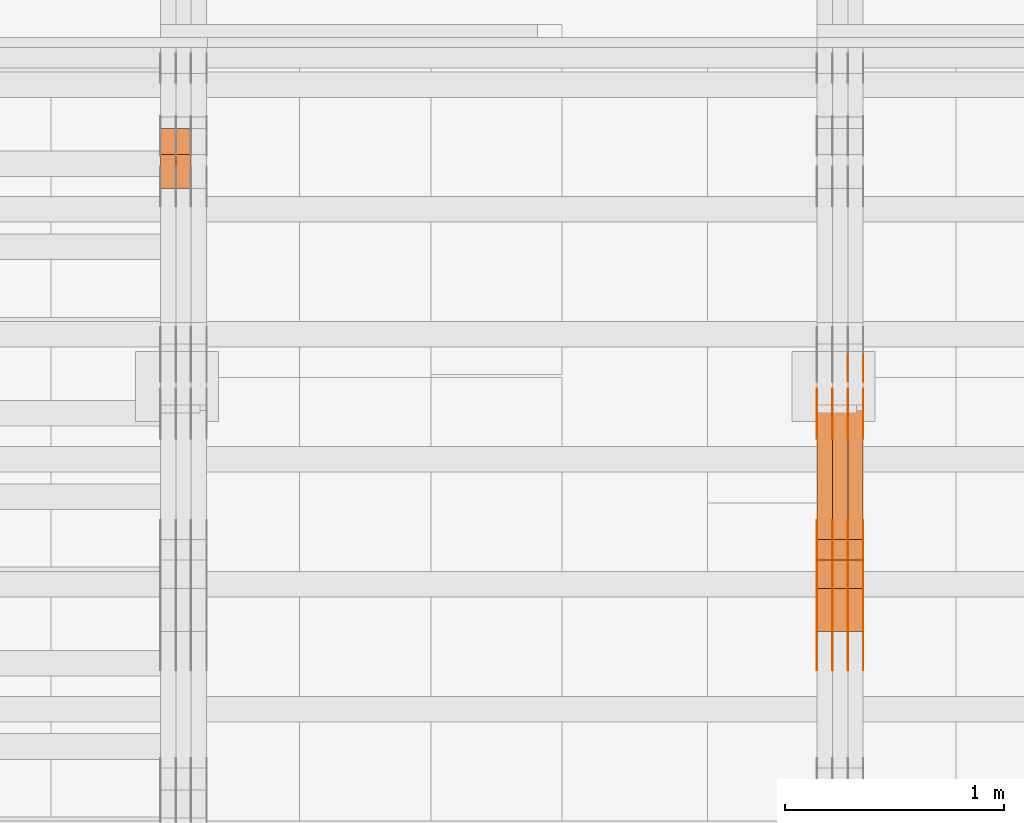
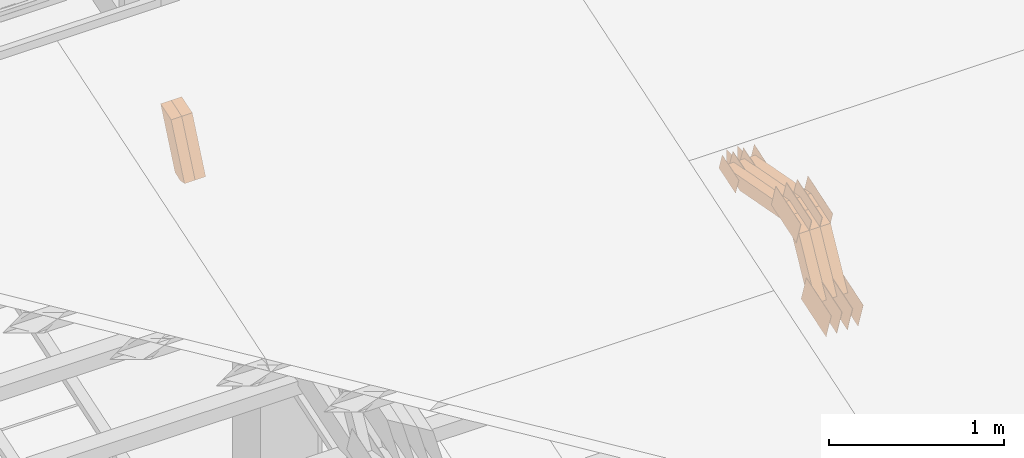
# One storey, part 79 of 385: 28 proxies.
"""IFC2X3 building model written with IfcOpenShell, lengths in millimetres."""

from ifc_helpers import new_model, entity, si_unit, converted_unit, derived_unit, direction, frame, frame_2d, origin, place, context, subcontext, project, spatial, polyline, rectangle, outline, extrude, source, transform, mapped, material, type_object, type_shapes, element, save


model = new_model("IFC2X3")

# Units and contexts
model_context = context("Model", 3, precision=0.01, world=origin(), true_north=direction((6.12303176911189e-17, 1.0)))
body_context = subcontext(model_context, "Body", "Model", "MODEL_VIEW")
ifc_project = project(units=[si_unit("LENGTHUNIT", "METRE", prefix="MILLI"), si_unit("AREAUNIT", "SQUARE_METRE"), si_unit("VOLUMEUNIT", "CUBIC_METRE"), converted_unit("PLANEANGLEUNIT", "DEGREE", entity("IfcRatioMeasure", 0.0174532925199433), si_unit("PLANEANGLEUNIT", "RADIAN"), dimensions=[0, 0, 0, 0, 0, 0, 0]), si_unit("MASSUNIT", "GRAM", prefix="KILO"), derived_unit("MASSDENSITYUNIT", [(si_unit("MASSUNIT", "GRAM", prefix="KILO"), 1), (si_unit("LENGTHUNIT", "METRE"), -3)]), si_unit("TIMEUNIT", "SECOND"), si_unit("FREQUENCYUNIT", "HERTZ"), si_unit("THERMODYNAMICTEMPERATUREUNIT", "DEGREE_CELSIUS"), derived_unit("THERMALTRANSMITTANCEUNIT", [(si_unit("MASSUNIT", "GRAM", prefix="KILO"), 1), (si_unit("THERMODYNAMICTEMPERATUREUNIT", "KELVIN"), -1), (si_unit("TIMEUNIT", "SECOND"), -3)]), derived_unit("VOLUMETRICFLOWRATEUNIT", [(si_unit("LENGTHUNIT", "METRE"), 3), (si_unit("TIMEUNIT", "SECOND"), -1)]), si_unit("ELECTRICCURRENTUNIT", "AMPERE"), si_unit("ELECTRICVOLTAGEUNIT", "VOLT"), si_unit("POWERUNIT", "WATT"), si_unit("FORCEUNIT", "NEWTON", prefix="KILO"), si_unit("ILLUMINANCEUNIT", "LUX"), si_unit("LUMINOUSFLUXUNIT", "LUMEN"), si_unit("LUMINOUSINTENSITYUNIT", "CANDELA"), derived_unit("USERDEFINED", [(si_unit("MASSUNIT", "GRAM", prefix="KILO"), -1), (si_unit("LENGTHUNIT", "METRE"), -2), (si_unit("TIMEUNIT", "SECOND"), 3), (si_unit("LUMINOUSFLUXUNIT", "LUMEN"), 1)]), derived_unit("LINEARVELOCITYUNIT", [(si_unit("LENGTHUNIT", "METRE"), 1), (si_unit("TIMEUNIT", "SECOND"), -1)]), si_unit("PRESSUREUNIT", "PASCAL"), derived_unit("USERDEFINED", [(si_unit("LENGTHUNIT", "METRE"), -2), (si_unit("MASSUNIT", "GRAM", prefix="KILO"), 1), (si_unit("TIMEUNIT", "SECOND"), -2)])], contexts=[model_context])

# Site, building, storey
site_placement = place(None, origin())
site = spatial("IfcSite", under=ifc_project, at=site_placement, CompositionType="ELEMENT")
building_placement = place(site_placement, origin())
building = spatial("IfcBuilding", under=site, at=building_placement, CompositionType="ELEMENT")
storey_placement = place(building_placement, origin())
storey = spatial("IfcBuildingStorey", under=building, at=storey_placement, Name="Default", CompositionType="ELEMENT", Elevation=0.0)

# Proxies
ifc_material_1 = material(Name="IfcSurfaceStyle #105160")
building_element_proxy_type_1 = type_object("IfcBuildingElementProxyType", PredefinedType="NOTDEFINED", material=ifc_material_1)
shared_shape_1 = source(origin(), body_context, "Body", "SweptSolid", [
    extrude(outline(polyline([(-149.99966632326, -95.9999759039407), (149.999881095801, -95.9999759039407), (150.000557367591, 95.9999759039407), (-150.000772140132, 95.9999759039406), (-149.99966632326, -95.9999759039407)])), frame((150.000557367591, 96.0004291135906, 0.0), z_axis=(0.0, 0.0, 1.0), x_axis=(-1.0, 0.0, 0.0)), (0.0, 0.0, 1.0), 1.29999999999999),
])
type_shapes(building_element_proxy_type_1, [shared_shape_1])
proxy_1_placement = place(building_placement, frame((6386.29999999999, 10934.7734375, 2766.8759765625), z_axis=(-1.0, 0.0, 0.0), x_axis=(0.0, 0.951056516295124, 0.309016994375039)))
element("IfcBuildingElementProxy", 1, at=proxy_1_placement, inside=storey, type_object=building_element_proxy_type_1, material=ifc_material_1, context=body_context, shape_type="MappedRepresentation", body=[
    mapped(shared_shape_1, transform((0.0, 0.0, 0.0), scale=1.0)),
])
ifc_material_2 = material(Name="IfcSurfaceStyle #105103")
building_element_proxy_type_2 = type_object("IfcBuildingElementProxyType", PredefinedType="NOTDEFINED", material=ifc_material_2)
shared_shape_2 = source(origin(), body_context, "Body", "SweptSolid", [
    extrude(outline(polyline([(-149.99966632326, -95.9999759039407), (149.999881095801, -95.9999759039407), (150.000557367591, 95.9999759039407), (-150.000772140132, 95.9999759039406), (-149.99966632326, -95.9999759039407)])), frame((150.000557367591, 96.0004291135906, 0.0), z_axis=(0.0, 0.0, 1.0), x_axis=(-1.0, 0.0, 0.0)), (0.0, 0.0, 1.0), 1.29999999999999),
])
type_shapes(building_element_proxy_type_2, [shared_shape_2])
proxy_2_placement = place(building_placement, frame((6315.0, 10934.7734375, 2766.8759765625), z_axis=(-1.0, 0.0, 0.0), x_axis=(0.0, 0.951056516295124, 0.309016994375039)))
element("IfcBuildingElementProxy", 2, at=proxy_2_placement, inside=storey, type_object=building_element_proxy_type_2, material=ifc_material_2, context=body_context, shape_type="MappedRepresentation", body=[
    mapped(shared_shape_2, transform((0.0, 0.0, 0.0), scale=1.0)),
])
ifc_material_3 = material(Name="IfcSurfaceStyle #105046")
building_element_proxy_type_3 = type_object("IfcBuildingElementProxyType", PredefinedType="NOTDEFINED", material=ifc_material_3)
shared_shape_3 = source(origin(), body_context, "Body", "SweptSolid", [
    extrude(outline(polyline([(-149.99966632326, -95.9999759039407), (149.999881095801, -95.9999759039407), (150.000557367591, 95.9999759039407), (-150.000772140132, 95.9999759039406), (-149.99966632326, -95.9999759039407)])), frame((150.000557367591, 96.0004291135906, 0.0), z_axis=(0.0, 0.0, 1.0), x_axis=(-1.0, 0.0, 0.0)), (0.0, 0.0, 1.0), 1.29999999999999),
])
type_shapes(building_element_proxy_type_3, [shared_shape_3])
proxy_3_placement = place(building_placement, frame((6316.29999999999, 10934.7734375, 2766.8759765625), z_axis=(-1.0, 0.0, 0.0), x_axis=(0.0, 0.951056516295124, 0.309016994375039)))
element("IfcBuildingElementProxy", 3, at=proxy_3_placement, inside=storey, type_object=building_element_proxy_type_3, material=ifc_material_3, context=body_context, shape_type="MappedRepresentation", body=[
    mapped(shared_shape_3, transform((0.0, 0.0, 0.0), scale=1.0)),
])
ifc_material_4 = material(Name="IfcSurfaceStyle #104989")
building_element_proxy_type_4 = type_object("IfcBuildingElementProxyType", PredefinedType="NOTDEFINED", material=ifc_material_4)
shared_shape_4 = source(origin(), body_context, "Body", "SweptSolid", [
    extrude(outline(polyline([(-149.99966632326, -95.9999759039407), (149.999881095801, -95.9999759039407), (150.000557367591, 95.9999759039407), (-150.000772140132, 95.9999759039406), (-149.99966632326, -95.9999759039407)])), frame((150.000557367591, 96.0004291135906, 0.0), z_axis=(0.0, 0.0, 1.0), x_axis=(-1.0, 0.0, 0.0)), (0.0, 0.0, 1.0), 1.29999999999998),
])
type_shapes(building_element_proxy_type_4, [shared_shape_4])
proxy_4_placement = place(building_placement, frame((6245.0, 10934.7734375, 2766.8759765625), z_axis=(-1.0, 0.0, 0.0), x_axis=(0.0, 0.951056516295124, 0.309016994375039)))
element("IfcBuildingElementProxy", 4, at=proxy_4_placement, inside=storey, type_object=building_element_proxy_type_4, material=ifc_material_4, context=body_context, shape_type="MappedRepresentation", body=[
    mapped(shared_shape_4, transform((0.0, 0.0, 0.0), scale=1.0)),
])
ifc_material_5 = material(Name="IfcSurfaceStyle #104932")
building_element_proxy_type_5 = type_object("IfcBuildingElementProxyType", PredefinedType="NOTDEFINED", material=ifc_material_5)
shared_shape_5 = source(origin(), body_context, "Body", "SweptSolid", [
    extrude(outline(polyline([(-149.99966632326, -95.9999759039407), (149.999881095801, -95.9999759039407), (150.000557367591, 95.9999759039407), (-150.000772140132, 95.9999759039406), (-149.99966632326, -95.9999759039407)])), frame((150.000557367591, 96.0004291135906, 0.0), z_axis=(0.0, 0.0, 1.0), x_axis=(-1.0, 0.0, 0.0)), (0.0, 0.0, 1.0), 1.29999999999998),
])
type_shapes(building_element_proxy_type_5, [shared_shape_5])
proxy_5_placement = place(building_placement, frame((6246.29999999999, 10934.7734375, 2766.8759765625), z_axis=(-1.0, 0.0, 0.0), x_axis=(0.0, 0.951056516295124, 0.309016994375039)))
element("IfcBuildingElementProxy", 5, at=proxy_5_placement, inside=storey, type_object=building_element_proxy_type_5, material=ifc_material_5, context=body_context, shape_type="MappedRepresentation", body=[
    mapped(shared_shape_5, transform((0.0, 0.0, 0.0), scale=1.0)),
])
ifc_material_6 = material(Name="IfcSurfaceStyle #104875")
building_element_proxy_type_6 = type_object("IfcBuildingElementProxyType", PredefinedType="NOTDEFINED", material=ifc_material_6)
shared_shape_6 = source(origin(), body_context, "Body", "SweptSolid", [
    extrude(outline(polyline([(-149.99966632326, -95.9999759039407), (149.999881095801, -95.9999759039407), (150.000557367591, 95.9999759039407), (-150.000772140132, 95.9999759039406), (-149.99966632326, -95.9999759039407)])), frame((150.000557367591, 96.0004291135906, 0.0), z_axis=(0.0, 0.0, 1.0), x_axis=(-1.0, 0.0, 0.0)), (0.0, 0.0, 1.0), 1.29999999999998),
])
type_shapes(building_element_proxy_type_6, [shared_shape_6])
proxy_6_placement = place(building_placement, frame((6175.0, 10934.7734375, 2766.8759765625), z_axis=(-1.0, 0.0, 0.0), x_axis=(0.0, 0.951056516295124, 0.309016994375039)))
element("IfcBuildingElementProxy", 6, at=proxy_6_placement, inside=storey, type_object=building_element_proxy_type_6, material=ifc_material_6, context=body_context, shape_type="MappedRepresentation", body=[
    mapped(shared_shape_6, transform((0.0, 0.0, 0.0), scale=1.0)),
])
ifc_material_7 = material(Name="IfcSurfaceStyle #103792")
building_element_proxy_type_7 = type_object("IfcBuildingElementProxyType", PredefinedType="NOTDEFINED", material=ifc_material_7)
shared_shape_7 = source(origin(), body_context, "Body", "SweptSolid", [
    extrude(outline(polyline([(-99.9997874178038, -60.0000528641967), (99.9998102700997, -60.0000528641967), (99.9998251396068, 60.0000528641967), (-99.9998479919027, 60.0000528641967), (-99.9997874178038, -60.0000528641967)])), frame((99.9999918898597, 60.0000528641967, 0.0), z_axis=(0.0, 0.0, 1.0), x_axis=(-1.0, 0.0, 0.0)), (0.0, 0.0, 1.0), 1.3),
])
type_shapes(building_element_proxy_type_7, [shared_shape_7])
proxy_7_placement = place(building_placement, frame((6386.29999999999, 11991.9568177725, 3072.52282247925), z_axis=(-1.0, 0.0, 0.0), x_axis=(0.0, 0.951056516295124, 0.309016994375039)))
element("IfcBuildingElementProxy", 7, at=proxy_7_placement, inside=storey, type_object=building_element_proxy_type_7, material=ifc_material_7, context=body_context, shape_type="MappedRepresentation", body=[
    mapped(shared_shape_7, transform((0.0, 0.0, 0.0), scale=1.0)),
])
ifc_material_8 = material(Name="IfcSurfaceStyle #103735")
building_element_proxy_type_8 = type_object("IfcBuildingElementProxyType", PredefinedType="NOTDEFINED", material=ifc_material_8)
shared_shape_8 = source(origin(), body_context, "Body", "SweptSolid", [
    extrude(outline(polyline([(-99.9997874178038, -60.0000528641967), (99.9998102700997, -60.0000528641967), (99.9998251396068, 60.0000528641967), (-99.9998479919027, 60.0000528641967), (-99.9997874178038, -60.0000528641967)])), frame((99.9999918898597, 60.0000528641967, 0.0), z_axis=(0.0, 0.0, 1.0), x_axis=(-1.0, 0.0, 0.0)), (0.0, 0.0, 1.0), 1.3),
])
type_shapes(building_element_proxy_type_8, [shared_shape_8])
proxy_8_placement = place(building_placement, frame((6315.0, 11991.9568177725, 3072.52282247925), z_axis=(-1.0, 0.0, 0.0), x_axis=(0.0, 0.951056516295124, 0.309016994375039)))
element("IfcBuildingElementProxy", 8, at=proxy_8_placement, inside=storey, type_object=building_element_proxy_type_8, material=ifc_material_8, context=body_context, shape_type="MappedRepresentation", body=[
    mapped(shared_shape_8, transform((0.0, 0.0, 0.0), scale=1.0)),
])
ifc_material_9 = material(Name="IfcSurfaceStyle #103678")
building_element_proxy_type_9 = type_object("IfcBuildingElementProxyType", PredefinedType="NOTDEFINED", material=ifc_material_9)
shared_shape_9 = source(origin(), body_context, "Body", "SweptSolid", [
    extrude(outline(polyline([(-99.9997874178038, -60.0000528641967), (99.9998102700997, -60.0000528641967), (99.9998251396068, 60.0000528641967), (-99.9998479919027, 60.0000528641967), (-99.9997874178038, -60.0000528641967)])), frame((99.9999918898597, 60.0000528641967, 0.0), z_axis=(0.0, 0.0, 1.0), x_axis=(-1.0, 0.0, 0.0)), (0.0, 0.0, 1.0), 1.3),
])
type_shapes(building_element_proxy_type_9, [shared_shape_9])
proxy_9_placement = place(building_placement, frame((6316.29999999999, 11991.9568177725, 3072.52282247925), z_axis=(-1.0, 0.0, 0.0), x_axis=(0.0, 0.951056516295124, 0.309016994375039)))
element("IfcBuildingElementProxy", 9, at=proxy_9_placement, inside=storey, type_object=building_element_proxy_type_9, material=ifc_material_9, context=body_context, shape_type="MappedRepresentation", body=[
    mapped(shared_shape_9, transform((0.0, 0.0, 0.0), scale=1.0)),
])
ifc_material_10 = material(Name="IfcSurfaceStyle #103621")
building_element_proxy_type_10 = type_object("IfcBuildingElementProxyType", PredefinedType="NOTDEFINED", material=ifc_material_10)
shared_shape_10 = source(origin(), body_context, "Body", "SweptSolid", [
    extrude(outline(polyline([(-99.9997874178038, -60.0000528641967), (99.9998102700997, -60.0000528641967), (99.9998251396068, 60.0000528641967), (-99.9998479919027, 60.0000528641967), (-99.9997874178038, -60.0000528641967)])), frame((99.9999918898597, 60.0000528641967, 0.0), z_axis=(0.0, 0.0, 1.0), x_axis=(-1.0, 0.0, 0.0)), (0.0, 0.0, 1.0), 1.29999999999998),
])
type_shapes(building_element_proxy_type_10, [shared_shape_10])
proxy_10_placement = place(building_placement, frame((6245.0, 11991.9568177725, 3072.52282247925), z_axis=(-1.0, 0.0, 0.0), x_axis=(0.0, 0.951056516295124, 0.309016994375039)))
element("IfcBuildingElementProxy", 10, at=proxy_10_placement, inside=storey, type_object=building_element_proxy_type_10, material=ifc_material_10, context=body_context, shape_type="MappedRepresentation", body=[
    mapped(shared_shape_10, transform((0.0, 0.0, 0.0), scale=1.0)),
])
ifc_material_11 = material(Name="IfcSurfaceStyle #103564")
building_element_proxy_type_11 = type_object("IfcBuildingElementProxyType", PredefinedType="NOTDEFINED", material=ifc_material_11)
shared_shape_11 = source(origin(), body_context, "Body", "SweptSolid", [
    extrude(outline(polyline([(-99.9997874178038, -60.0000528641967), (99.9998102700997, -60.0000528641967), (99.9998251396068, 60.0000528641967), (-99.9998479919027, 60.0000528641967), (-99.9997874178038, -60.0000528641967)])), frame((99.9999918898597, 60.0000528641967, 0.0), z_axis=(0.0, 0.0, 1.0), x_axis=(-1.0, 0.0, 0.0)), (0.0, 0.0, 1.0), 1.29999999999998),
])
type_shapes(building_element_proxy_type_11, [shared_shape_11])
proxy_11_placement = place(building_placement, frame((6246.29999999999, 11991.9568177725, 3072.52282247925), z_axis=(-1.0, 0.0, 0.0), x_axis=(0.0, 0.951056516295124, 0.309016994375039)))
element("IfcBuildingElementProxy", 11, at=proxy_11_placement, inside=storey, type_object=building_element_proxy_type_11, material=ifc_material_11, context=body_context, shape_type="MappedRepresentation", body=[
    mapped(shared_shape_11, transform((0.0, 0.0, 0.0), scale=1.0)),
])
ifc_material_12 = material(Name="IfcSurfaceStyle #103507")
building_element_proxy_type_12 = type_object("IfcBuildingElementProxyType", PredefinedType="NOTDEFINED", material=ifc_material_12)
shared_shape_12 = source(origin(), body_context, "Body", "SweptSolid", [
    extrude(outline(polyline([(-99.9997874178038, -60.0000528641967), (99.9998102700997, -60.0000528641967), (99.9998251396068, 60.0000528641967), (-99.9998479919027, 60.0000528641967), (-99.9997874178038, -60.0000528641967)])), frame((99.9999918898597, 60.0000528641967, 0.0), z_axis=(0.0, 0.0, 1.0), x_axis=(-1.0, 0.0, 0.0)), (0.0, 0.0, 1.0), 1.29999999999999),
])
type_shapes(building_element_proxy_type_12, [shared_shape_12])
proxy_12_placement = place(building_placement, frame((6175.0, 11991.9568177725, 3072.52282247925), z_axis=(-1.0, 0.0, 0.0), x_axis=(0.0, 0.951056516295124, 0.309016994375039)))
element("IfcBuildingElementProxy", 12, at=proxy_12_placement, inside=storey, type_object=building_element_proxy_type_12, material=ifc_material_12, context=body_context, shape_type="MappedRepresentation", body=[
    mapped(shared_shape_12, transform((0.0, 0.0, 0.0), scale=1.0)),
])
ifc_material_13 = material(Name="IfcSurfaceStyle #103450")
building_element_proxy_type_13 = type_object("IfcBuildingElementProxyType", PredefinedType="NOTDEFINED", material=ifc_material_13)
shared_shape_13 = source(origin(), body_context, "Body", "SweptSolid", [
    extrude(rectangle(XDim=150.0, YDim=119.999999999985, at=frame_2d((-7.105427357601e-15, 0.0), x_axis=(1.0, 0.0))), frame((75.0, 60.0, 0.0), z_axis=(0.0, 0.0, 1.0), x_axis=(-1.0, 0.0, 0.0)), (0.0, 0.0, 1.0), 1.3),
])
type_shapes(building_element_proxy_type_13, [shared_shape_13])
proxy_13_placement = place(building_placement, frame((6386.29999999999, 12372.95703125, 3007.04687500001), z_axis=(-1.0, 0.0, 0.0), x_axis=(0.0, 0.0, -1.0)))
element("IfcBuildingElementProxy", 13, at=proxy_13_placement, inside=storey, type_object=building_element_proxy_type_13, material=ifc_material_13, context=body_context, shape_type="MappedRepresentation", body=[
    mapped(shared_shape_13, transform((0.0, 0.0, 0.0), scale=1.0)),
])
ifc_material_14 = material(Name="IfcSurfaceStyle #103393")
building_element_proxy_type_14 = type_object("IfcBuildingElementProxyType", PredefinedType="NOTDEFINED", material=ifc_material_14)
shared_shape_14 = source(origin(), body_context, "Body", "SweptSolid", [
    extrude(rectangle(XDim=150.0, YDim=119.999999999985, at=frame_2d((-7.105427357601e-15, 0.0), x_axis=(1.0, 0.0))), frame((75.0, 60.0, 0.0), z_axis=(0.0, 0.0, 1.0), x_axis=(-1.0, 0.0, 0.0)), (0.0, 0.0, 1.0), 1.3),
])
type_shapes(building_element_proxy_type_14, [shared_shape_14])
proxy_14_placement = place(building_placement, frame((6315.0, 12372.95703125, 3007.04687500001), z_axis=(-1.0, 0.0, 0.0), x_axis=(0.0, 0.0, -1.0)))
element("IfcBuildingElementProxy", 14, at=proxy_14_placement, inside=storey, type_object=building_element_proxy_type_14, material=ifc_material_14, context=body_context, shape_type="MappedRepresentation", body=[
    mapped(shared_shape_14, transform((0.0, 0.0, 0.0), scale=1.0)),
])
ifc_material_15 = material(Name="IfcSurfaceStyle #95584")
building_element_proxy_type_15 = type_object("IfcBuildingElementProxyType", PredefinedType="NOTDEFINED", material=ifc_material_15)
shared_shape_15 = source(origin(), body_context, "Body", "SweptSolid", [
    extrude(outline(polyline([(-150.000273478628, -84.0002987844282), (149.999198496832, -84.0002987844282), (150.000273478627, 84.0002987844282), (-149.999198496831, 84.0002987844282), (-150.000273478628, -84.0002987844282)])), frame((150.000273478627, 84.0002987844282, 0.0), z_axis=(0.0, 0.0, 1.0), x_axis=(-1.0, 0.0, 0.0)), (0.0, 0.0, 1.0), 1.29999999999999),
])
type_shapes(building_element_proxy_type_15, [shared_shape_15])
proxy_15_placement = place(building_placement, frame((6386.29999999999, 11283.0116722926, 3194.09682266857), z_axis=(-1.0, 0.0, 0.0), x_axis=(0.0, 0.951056516295154, 0.309016994374948)))
element("IfcBuildingElementProxy", 15, at=proxy_15_placement, inside=storey, type_object=building_element_proxy_type_15, material=ifc_material_15, context=body_context, shape_type="MappedRepresentation", body=[
    mapped(shared_shape_15, transform((0.0, 0.0, 0.0), scale=1.0)),
])
ifc_material_16 = material(Name="IfcSurfaceStyle #95527")
building_element_proxy_type_16 = type_object("IfcBuildingElementProxyType", PredefinedType="NOTDEFINED", material=ifc_material_16)
shared_shape_16 = source(origin(), body_context, "Body", "SweptSolid", [
    extrude(outline(polyline([(-150.000273478628, -84.0002987844282), (149.999198496832, -84.0002987844282), (150.000273478627, 84.0002987844282), (-149.999198496831, 84.0002987844282), (-150.000273478628, -84.0002987844282)])), frame((150.000273478627, 84.0002987844282, 0.0), z_axis=(0.0, 0.0, 1.0), x_axis=(-1.0, 0.0, 0.0)), (0.0, 0.0, 1.0), 1.29999999999999),
])
type_shapes(building_element_proxy_type_16, [shared_shape_16])
proxy_16_placement = place(building_placement, frame((6315.0, 11283.0116722926, 3194.09682266857), z_axis=(-1.0, 0.0, 0.0), x_axis=(0.0, 0.951056516295154, 0.309016994374948)))
element("IfcBuildingElementProxy", 16, at=proxy_16_placement, inside=storey, type_object=building_element_proxy_type_16, material=ifc_material_16, context=body_context, shape_type="MappedRepresentation", body=[
    mapped(shared_shape_16, transform((0.0, 0.0, 0.0), scale=1.0)),
])
ifc_material_17 = material(Name="IfcSurfaceStyle #95470")
building_element_proxy_type_17 = type_object("IfcBuildingElementProxyType", PredefinedType="NOTDEFINED", material=ifc_material_17)
shared_shape_17 = source(origin(), body_context, "Body", "SweptSolid", [
    extrude(outline(polyline([(-150.000273478628, -84.0002987844282), (149.999198496832, -84.0002987844282), (150.000273478627, 84.0002987844282), (-149.999198496831, 84.0002987844282), (-150.000273478628, -84.0002987844282)])), frame((150.000273478627, 84.0002987844282, 0.0), z_axis=(0.0, 0.0, 1.0), x_axis=(-1.0, 0.0, 0.0)), (0.0, 0.0, 1.0), 1.29999999999999),
])
type_shapes(building_element_proxy_type_17, [shared_shape_17])
proxy_17_placement = place(building_placement, frame((6316.29999999999, 11283.0116722926, 3194.09682266857), z_axis=(-1.0, 0.0, 0.0), x_axis=(0.0, 0.951056516295154, 0.309016994374948)))
element("IfcBuildingElementProxy", 17, at=proxy_17_placement, inside=storey, type_object=building_element_proxy_type_17, material=ifc_material_17, context=body_context, shape_type="MappedRepresentation", body=[
    mapped(shared_shape_17, transform((0.0, 0.0, 0.0), scale=1.0)),
])
ifc_material_18 = material(Name="IfcSurfaceStyle #95413")
building_element_proxy_type_18 = type_object("IfcBuildingElementProxyType", PredefinedType="NOTDEFINED", material=ifc_material_18)
shared_shape_18 = source(origin(), body_context, "Body", "SweptSolid", [
    extrude(outline(polyline([(-150.000273478628, -84.0002987844282), (149.999198496832, -84.0002987844282), (150.000273478627, 84.0002987844282), (-149.999198496831, 84.0002987844282), (-150.000273478628, -84.0002987844282)])), frame((150.000273478627, 84.0002987844282, 0.0), z_axis=(0.0, 0.0, 1.0), x_axis=(-1.0, 0.0, 0.0)), (0.0, 0.0, 1.0), 1.29999999999998),
])
type_shapes(building_element_proxy_type_18, [shared_shape_18])
proxy_18_placement = place(building_placement, frame((6245.0, 11283.0116722926, 3194.09682266857), z_axis=(-1.0, 0.0, 0.0), x_axis=(0.0, 0.951056516295154, 0.309016994374948)))
element("IfcBuildingElementProxy", 18, at=proxy_18_placement, inside=storey, type_object=building_element_proxy_type_18, material=ifc_material_18, context=body_context, shape_type="MappedRepresentation", body=[
    mapped(shared_shape_18, transform((0.0, 0.0, 0.0), scale=1.0)),
])
ifc_material_19 = material(Name="IfcSurfaceStyle #95356")
building_element_proxy_type_19 = type_object("IfcBuildingElementProxyType", PredefinedType="NOTDEFINED", material=ifc_material_19)
shared_shape_19 = source(origin(), body_context, "Body", "SweptSolid", [
    extrude(outline(polyline([(-150.000273478628, -84.0002987844282), (149.999198496832, -84.0002987844282), (150.000273478627, 84.0002987844282), (-149.999198496831, 84.0002987844282), (-150.000273478628, -84.0002987844282)])), frame((150.000273478627, 84.0002987844282, 0.0), z_axis=(0.0, 0.0, 1.0), x_axis=(-1.0, 0.0, 0.0)), (0.0, 0.0, 1.0), 1.29999999999998),
])
type_shapes(building_element_proxy_type_19, [shared_shape_19])
proxy_19_placement = place(building_placement, frame((6246.29999999999, 11283.0116722926, 3194.09682266857), z_axis=(-1.0, 0.0, 0.0), x_axis=(0.0, 0.951056516295154, 0.309016994374948)))
element("IfcBuildingElementProxy", 19, at=proxy_19_placement, inside=storey, type_object=building_element_proxy_type_19, material=ifc_material_19, context=body_context, shape_type="MappedRepresentation", body=[
    mapped(shared_shape_19, transform((0.0, 0.0, 0.0), scale=1.0)),
])
ifc_material_20 = material(Name="IfcSurfaceStyle #95299")
building_element_proxy_type_20 = type_object("IfcBuildingElementProxyType", PredefinedType="NOTDEFINED", material=ifc_material_20)
shared_shape_20 = source(origin(), body_context, "Body", "SweptSolid", [
    extrude(outline(polyline([(-150.000273478628, -84.0002987844282), (149.999198496832, -84.0002987844282), (150.000273478627, 84.0002987844282), (-149.999198496831, 84.0002987844282), (-150.000273478628, -84.0002987844282)])), frame((150.000273478627, 84.0002987844282, 0.0), z_axis=(0.0, 0.0, 1.0), x_axis=(-1.0, 0.0, 0.0)), (0.0, 0.0, 1.0), 1.29999999999998),
])
type_shapes(building_element_proxy_type_20, [shared_shape_20])
proxy_20_placement = place(building_placement, frame((6175.0, 11283.0116722926, 3194.09682266857), z_axis=(-1.0, 0.0, 0.0), x_axis=(0.0, 0.951056516295154, 0.309016994374948)))
element("IfcBuildingElementProxy", 20, at=proxy_20_placement, inside=storey, type_object=building_element_proxy_type_20, material=ifc_material_20, context=body_context, shape_type="MappedRepresentation", body=[
    mapped(shared_shape_20, transform((0.0, 0.0, 0.0), scale=1.0)),
])
ifc_material_21 = material(Name="IfcSurfaceStyle #85288")
building_element_proxy_type_21 = type_object("IfcBuildingElementProxyType", Name="T1-W9 85286", PredefinedType="NOTDEFINED", material=ifc_material_21)
shared_shape_21 = source(origin(), body_context, "Body", "SweptSolid", [
    extrude(outline(polyline([(-287.457507623288, -47.5000268597988), (288.590479960635, -47.5000268597988), (273.55062971372, -2.33146189358546e-05), (186.625054999886, 47.5000385171083), (-461.308657050953, 47.5000385171083), (-287.457507623288, -47.5000268597988)])), frame((288.590945855618, 47.5000968036551, 0.0), z_axis=(0.0, 0.0, 1.0), x_axis=(-1.0, 0.0, 0.0)), (0.0, 0.0, 1.0), 70.0),
])
type_shapes(building_element_proxy_type_21, [shared_shape_21])
proxy_21_placement = place(building_placement, frame((6385.0, 11432.1200855376, 3205.63308612017), z_axis=(-1.0, 0.0, 0.0), x_axis=(0.0, 0.982760503514031, -0.184883186722992)))
element("IfcBuildingElementProxy", 21, at=proxy_21_placement, inside=storey, type_object=building_element_proxy_type_21, material=ifc_material_21, Name="T1-W9", context=body_context, shape_type="MappedRepresentation", body=[
    mapped(shared_shape_21, transform((0.0, 0.0, 0.0), scale=1.0)),
])
ifc_material_22 = material(Name="IfcSurfaceStyle #85222")
building_element_proxy_type_22 = type_object("IfcBuildingElementProxyType", Name="T1-W9 85220", PredefinedType="NOTDEFINED", material=ifc_material_22)
shared_shape_22 = source(origin(), body_context, "Body", "SweptSolid", [
    extrude(outline(polyline([(-287.457507623288, -47.5000268597988), (288.590479960635, -47.5000268597988), (273.55062971372, -2.33146189358546e-05), (186.625054999886, 47.5000385171083), (-461.308657050953, 47.5000385171083), (-287.457507623288, -47.5000268597988)])), frame((288.590945855618, 47.5000968036551, 0.0), z_axis=(0.0, 0.0, 1.0), x_axis=(-1.0, 0.0, 0.0)), (0.0, 0.0, 1.0), 70.0),
])
type_shapes(building_element_proxy_type_22, [shared_shape_22])
proxy_22_placement = place(building_placement, frame((6315.0, 11432.1200855376, 3205.63308612017), z_axis=(-1.0, 0.0, 0.0), x_axis=(0.0, 0.982760503514031, -0.184883186722992)))
element("IfcBuildingElementProxy", 22, at=proxy_22_placement, inside=storey, type_object=building_element_proxy_type_22, material=ifc_material_22, Name="T1-W9", context=body_context, shape_type="MappedRepresentation", body=[
    mapped(shared_shape_22, transform((0.0, 0.0, 0.0), scale=1.0)),
])
ifc_material_23 = material(Name="IfcSurfaceStyle #85156")
building_element_proxy_type_23 = type_object("IfcBuildingElementProxyType", Name="T1-W9 85154", PredefinedType="NOTDEFINED", material=ifc_material_23)
shared_shape_23 = source(origin(), body_context, "Body", "SweptSolid", [
    extrude(outline(polyline([(-287.457507623288, -47.5000268597988), (288.590479960635, -47.5000268597988), (273.55062971372, -2.33146189358546e-05), (186.625054999886, 47.5000385171083), (-461.308657050953, 47.5000385171083), (-287.457507623288, -47.5000268597988)])), frame((288.590945855618, 47.5000968036551, 0.0), z_axis=(0.0, 0.0, 1.0), x_axis=(-1.0, 0.0, 0.0)), (0.0, 0.0, 1.0), 70.0),
])
type_shapes(building_element_proxy_type_23, [shared_shape_23])
proxy_23_placement = place(building_placement, frame((6245.0, 11432.1200855376, 3205.63308612017), z_axis=(-1.0, 0.0, 0.0), x_axis=(0.0, 0.982760503514031, -0.184883186722992)))
element("IfcBuildingElementProxy", 23, at=proxy_23_placement, inside=storey, type_object=building_element_proxy_type_23, material=ifc_material_23, Name="T1-W9", context=body_context, shape_type="MappedRepresentation", body=[
    mapped(shared_shape_23, transform((0.0, 0.0, 0.0), scale=1.0)),
])
ifc_material_24 = material(Name="IfcSurfaceStyle #84892")
building_element_proxy_type_24 = type_object("IfcBuildingElementProxyType", Name="T1-W32 84890", PredefinedType="NOTDEFINED", material=ifc_material_24)
shared_shape_24 = source(origin(), body_context, "Body", "SweptSolid", [
    extrude(outline(polyline([(-312.414547135921, -47.5000544873059), (136.677011757652, -47.5000544873059), (186.250996577889, 0.000369497452627243), (202.753116295831, 47.4998697385796), (-213.26657749545, 47.4998697385796), (-312.414547135921, -47.5000544873059)])), frame((202.753376481939, 47.5001296985553, 0.0), z_axis=(0.0, 0.0, 1.0), x_axis=(-1.0, 0.0, 0.0)), (0.0, 0.0, 1.0), 70.0),
])
type_shapes(building_element_proxy_type_24, [shared_shape_24])
proxy_24_placement = place(building_placement, frame((6385.0, 11110.7808979007, 2747.18129017315), z_axis=(-1.0, 0.0, 0.0), x_axis=(0.0, 0.472919689385906, 0.881105537033526)))
element("IfcBuildingElementProxy", 24, at=proxy_24_placement, inside=storey, type_object=building_element_proxy_type_24, material=ifc_material_24, Name="T1-W32", context=body_context, shape_type="MappedRepresentation", body=[
    mapped(shared_shape_24, transform((0.0, 0.0, 0.0), scale=1.0)),
])
ifc_material_25 = material(Name="IfcSurfaceStyle #84826")
building_element_proxy_type_25 = type_object("IfcBuildingElementProxyType", Name="T1-W32 84824", PredefinedType="NOTDEFINED", material=ifc_material_25)
shared_shape_25 = source(origin(), body_context, "Body", "SweptSolid", [
    extrude(outline(polyline([(-312.414547135921, -47.5000544873059), (136.677011757652, -47.5000544873059), (186.250996577889, 0.000369497452627243), (202.753116295831, 47.4998697385796), (-213.26657749545, 47.4998697385796), (-312.414547135921, -47.5000544873059)])), frame((202.753376481939, 47.5001296985553, 0.0), z_axis=(0.0, 0.0, 1.0), x_axis=(-1.0, 0.0, 0.0)), (0.0, 0.0, 1.0), 70.0),
])
type_shapes(building_element_proxy_type_25, [shared_shape_25])
proxy_25_placement = place(building_placement, frame((6315.0, 11110.7808979007, 2747.18129017315), z_axis=(-1.0, 0.0, 0.0), x_axis=(0.0, 0.472919689385906, 0.881105537033526)))
element("IfcBuildingElementProxy", 25, at=proxy_25_placement, inside=storey, type_object=building_element_proxy_type_25, material=ifc_material_25, Name="T1-W32", context=body_context, shape_type="MappedRepresentation", body=[
    mapped(shared_shape_25, transform((0.0, 0.0, 0.0), scale=1.0)),
])
ifc_material_26 = material(Name="IfcSurfaceStyle #84760")
building_element_proxy_type_26 = type_object("IfcBuildingElementProxyType", Name="T1-W32 84758", PredefinedType="NOTDEFINED", material=ifc_material_26)
shared_shape_26 = source(origin(), body_context, "Body", "SweptSolid", [
    extrude(outline(polyline([(-312.414547135921, -47.5000544873059), (136.677011757652, -47.5000544873059), (186.250996577889, 0.000369497452627243), (202.753116295831, 47.4998697385796), (-213.26657749545, 47.4998697385796), (-312.414547135921, -47.5000544873059)])), frame((202.753376481939, 47.5001296985553, 0.0), z_axis=(0.0, 0.0, 1.0), x_axis=(-1.0, 0.0, 0.0)), (0.0, 0.0, 1.0), 70.0),
])
type_shapes(building_element_proxy_type_26, [shared_shape_26])
proxy_26_placement = place(building_placement, frame((6245.0, 11110.7808979007, 2747.18129017315), z_axis=(-1.0, 0.0, 0.0), x_axis=(0.0, 0.472919689385906, 0.881105537033526)))
element("IfcBuildingElementProxy", 26, at=proxy_26_placement, inside=storey, type_object=building_element_proxy_type_26, material=ifc_material_26, Name="T1-W32", context=body_context, shape_type="MappedRepresentation", body=[
    mapped(shared_shape_26, transform((0.0, 0.0, 0.0), scale=1.0)),
])
ifc_material_27 = material(Name="IfcSurfaceStyle #51978")
building_element_proxy_type_27 = type_object("IfcBuildingElementProxyType", Name="T1-W42 51976", PredefinedType="NOTDEFINED", material=ifc_material_27)
shared_shape_27 = source(origin(), body_context, "Body", "SweptSolid", [
    extrude(outline(polyline([(-284.837590197601, -47.4997543607933), (129.95880168156, -47.4997543607933), (171.972324990451, 0.000162623346093338), (183.717007105413, 47.4996730491203), (-200.810543579822, 47.4996730491203), (-284.837590197601, -47.4997543607933)])), frame((183.717155718752, 47.4999821655365, 0.0), z_axis=(0.0, 0.0, 1.0), x_axis=(-1.0, 0.0, 0.0)), (0.0, 0.0, 1.0), 70.0),
])
type_shapes(building_element_proxy_type_27, [shared_shape_27])
proxy_27_placement = place(building_placement, frame((3315.0, 13135.8834463264, 3404.958483022), z_axis=(-1.0, 0.0, 0.0), x_axis=(0.0, 0.398630596470292, 0.917111578575769)))
element("IfcBuildingElementProxy", 27, at=proxy_27_placement, inside=storey, type_object=building_element_proxy_type_27, material=ifc_material_27, Name="T1-W42", context=body_context, shape_type="MappedRepresentation", body=[
    mapped(shared_shape_27, transform((0.0, 0.0, 0.0), scale=1.0)),
])
ifc_material_28 = material(Name="IfcSurfaceStyle #51912")
building_element_proxy_type_28 = type_object("IfcBuildingElementProxyType", Name="T1-W42 51910", PredefinedType="NOTDEFINED", material=ifc_material_28)
shared_shape_28 = source(origin(), body_context, "Body", "SweptSolid", [
    extrude(outline(polyline([(-284.837590197601, -47.4997543607933), (129.95880168156, -47.4997543607933), (171.972324990451, 0.000162623346093338), (183.717007105413, 47.4996730491203), (-200.810543579822, 47.4996730491203), (-284.837590197601, -47.4997543607933)])), frame((183.717155718752, 47.4999821655365, 0.0), z_axis=(0.0, 0.0, 1.0), x_axis=(-1.0, 0.0, 0.0)), (0.0, 0.0, 1.0), 70.0),
])
type_shapes(building_element_proxy_type_28, [shared_shape_28])
proxy_28_placement = place(building_placement, frame((3245.0, 13135.8834463264, 3404.958483022), z_axis=(-1.0, 0.0, 0.0), x_axis=(0.0, 0.398630596470292, 0.917111578575769)))
element("IfcBuildingElementProxy", 28, at=proxy_28_placement, inside=storey, type_object=building_element_proxy_type_28, material=ifc_material_28, Name="T1-W42", context=body_context, shape_type="MappedRepresentation", body=[
    mapped(shared_shape_28, transform((0.0, 0.0, 0.0), scale=1.0)),
])

save(model, "model.ifc")
